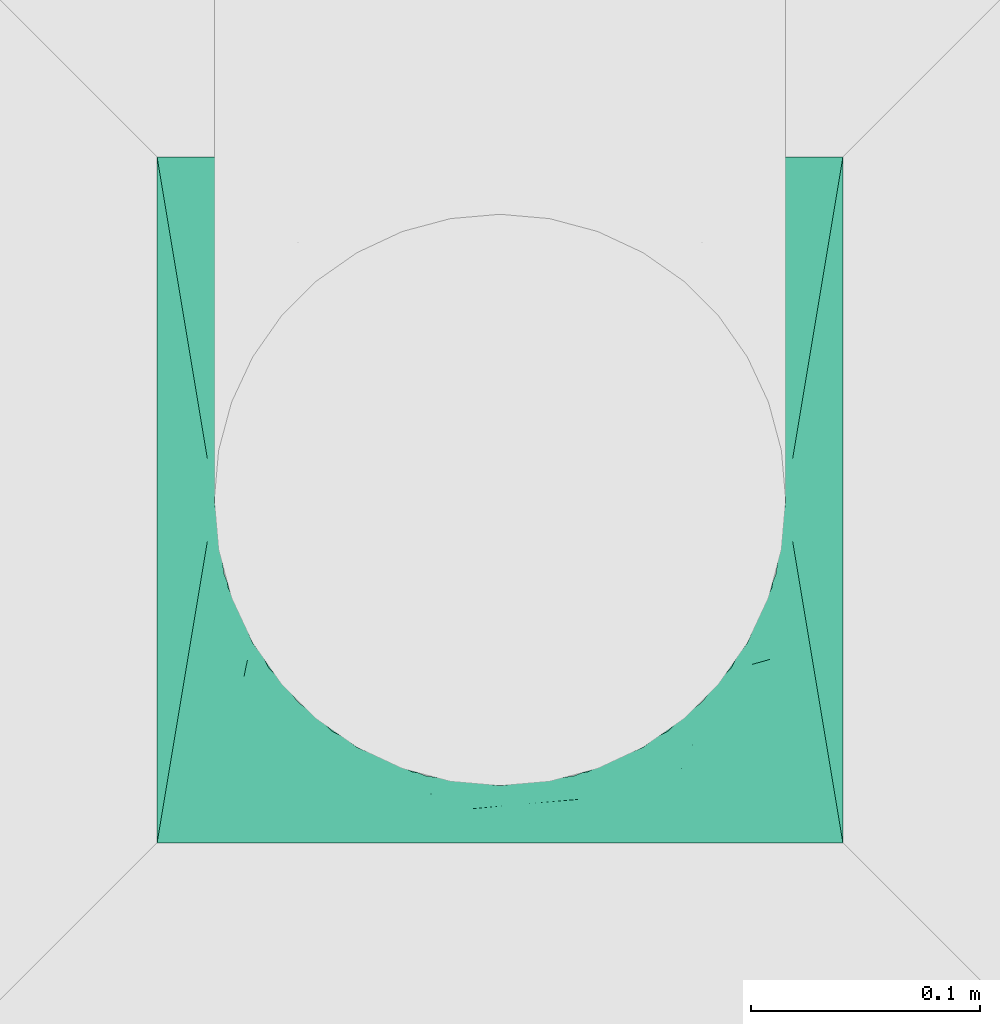
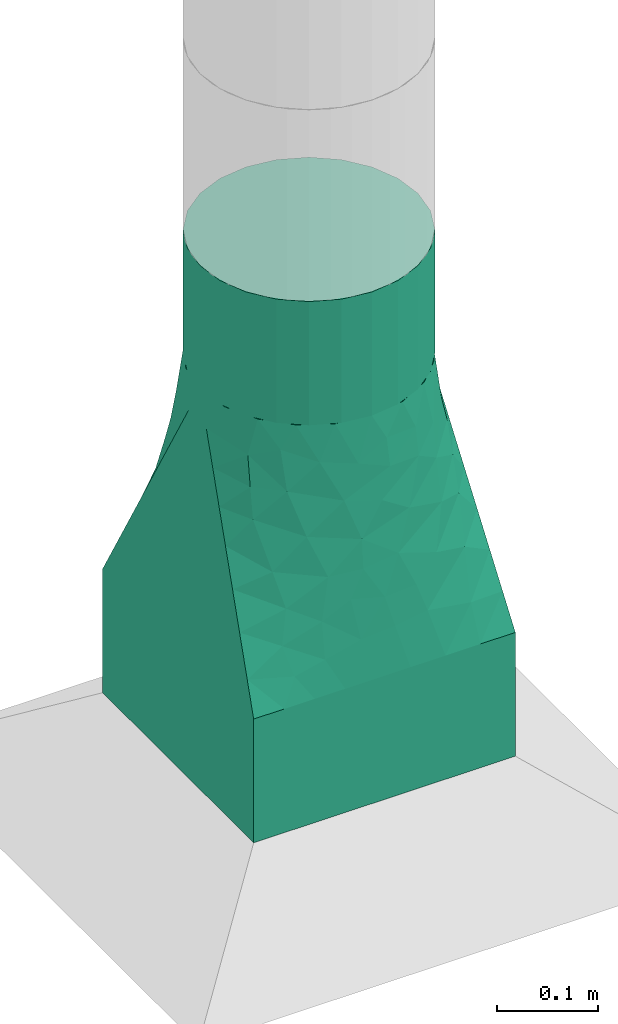
# One storey, part 3 of 6: 1 flow fitting.
"""IFC2X3 building model written with IfcOpenShell, lengths in metres."""

from ifc_helpers import new_model, entity, si_unit, converted_unit, derived_unit, direction, frame, origin, place, context, subcontext, project, spatial, faceted_brep, source, transform, mapped, type_object, type_shapes, element, save


model = new_model("IFC2X3")

# Units and contexts
model_context = context("Model", 3, precision=1e-05, world=origin(), true_north=direction((6.12303176911189e-17, 1.0)))
body_context = subcontext(model_context, "Body", "Model", "MODEL_VIEW")
ifc_project = project(units=[si_unit("LENGTHUNIT", "METRE"), si_unit("AREAUNIT", "SQUARE_METRE"), si_unit("VOLUMEUNIT", "CUBIC_METRE"), converted_unit("PLANEANGLEUNIT", "DEGREE", entity("IfcRatioMeasure", 0.0174532925199433), si_unit("PLANEANGLEUNIT", "RADIAN"), dimensions=[0, 0, 0, 0, 0, 0, 0]), si_unit("MASSUNIT", "GRAM", prefix="KILO"), derived_unit("MASSDENSITYUNIT", [(si_unit("MASSUNIT", "GRAM", prefix="KILO"), 1), (si_unit("LENGTHUNIT", "METRE"), -3)]), si_unit("TIMEUNIT", "SECOND"), si_unit("FREQUENCYUNIT", "HERTZ"), si_unit("THERMODYNAMICTEMPERATUREUNIT", "DEGREE_CELSIUS"), derived_unit("THERMALTRANSMITTANCEUNIT", [(si_unit("MASSUNIT", "GRAM", prefix="KILO"), 1), (si_unit("THERMODYNAMICTEMPERATUREUNIT", "KELVIN"), -1), (si_unit("TIMEUNIT", "SECOND"), -3)]), derived_unit("VOLUMETRICFLOWRATEUNIT", [(si_unit("LENGTHUNIT", "METRE"), 3), (si_unit("TIMEUNIT", "SECOND"), -1)]), si_unit("ELECTRICCURRENTUNIT", "AMPERE"), si_unit("ELECTRICVOLTAGEUNIT", "VOLT"), si_unit("POWERUNIT", "WATT"), si_unit("FORCEUNIT", "NEWTON", prefix="KILO"), si_unit("ILLUMINANCEUNIT", "LUX"), si_unit("LUMINOUSFLUXUNIT", "LUMEN"), si_unit("LUMINOUSINTENSITYUNIT", "CANDELA"), derived_unit("USERDEFINED", [(si_unit("MASSUNIT", "GRAM", prefix="KILO"), -1), (si_unit("LENGTHUNIT", "METRE"), -2), (si_unit("TIMEUNIT", "SECOND"), 3), (si_unit("LUMINOUSFLUXUNIT", "LUMEN"), 1)]), derived_unit("LINEARVELOCITYUNIT", [(si_unit("LENGTHUNIT", "METRE"), 1), (si_unit("TIMEUNIT", "SECOND"), -1)]), si_unit("PRESSUREUNIT", "PASCAL"), derived_unit("USERDEFINED", [(si_unit("LENGTHUNIT", "METRE"), -2), (si_unit("MASSUNIT", "GRAM", prefix="KILO"), 1), (si_unit("TIMEUNIT", "SECOND"), -2)])], contexts=[model_context])

# Site, building, storey
site_placement = place(None, origin())
site = spatial("IfcSite", under=ifc_project, at=site_placement, CompositionType="ELEMENT")
building_placement = place(site_placement, origin())
building = spatial("IfcBuilding", under=site, at=building_placement, CompositionType="ELEMENT")
storey_placement = place(building_placement, origin())
storey = spatial("IfcBuildingStorey", under=building, at=storey_placement, Name="1 - RDC", CompositionType="ELEMENT", Elevation=1.94210219716249e-13)

# Flow fitting
duct_fitting_type = type_object("IfcDuctFittingType", Name="Standard", PredefinedType="NOTDEFINED")
shared_shape = source(origin(), body_context, "Body", "Brep", [
    faceted_brep([(0.6, 0.0323523806378222, -0.120740728286125), (0.6, 0.0625000000000071, -0.108253175473047), (0.6, 0.0883883476483257, -0.0883883476483103), (0.6, 0.108253175473062, -0.062499999999992), (0.6, 0.120740728286141, -0.0323523806378072), (0.6, 0.125000000000008, 0.0), (0.6, 0.120740728286141, 0.0323523806378237), (0.6, 0.108253175473063, 0.0625000000000085), (0.6, 0.0883883476483262, 0.088388347648327), (0.6, 0.0625000000000078, 0.108253175473063), (0.6, 0.032352380637823, 0.120740728286142), (0.6, 0.0, 0.125000000000009), (0.6, -0.0323523806378072, 0.120740728286142), (0.6, -0.0624999999999921, 0.108253175473064), (0.6, -0.0883883476483105, 0.0883883476483273), (0.6, -0.108253175473047, 0.0625000000000089), (0.6, -0.120740728286126, 0.0323523806378241), (0.6, -0.124999999999992, 0.0), (0.6, -0.120740728286126, -0.0323523806378061), (0.6, -0.108253175473047, -0.062499999999991), (0.6, -0.0883883476483111, -0.0883883476483095), (0.6, -0.0624999999999927, -0.108253175473046), (0.6, -0.0323523806378079, -0.120740728286125), (0.6, 0.0, -0.124999999999991), (0.45, 0.032352380637823, 0.120740728286142), (0.45, 0.0625000000000078, 0.108253175473063), (0.45, 0.0883883476483262, 0.088388347648327), (0.45, 0.108253175473063, 0.0625000000000085), (0.45, 0.120740728286141, 0.0323523806378237), (0.45, 0.125000000000008, 0.0), (0.45, 0.120740728286141, -0.0323523806378072), (0.45, 0.108253175473062, -0.062499999999992), (0.45, 0.0883883476483257, -0.0883883476483103), (0.45, 0.0625000000000071, -0.108253175473047), (0.45, 0.0323523806378222, -0.120740728286125), (0.45, 0.0, -0.124999999999991), (0.45, -0.0323523806378079, -0.120740728286125), (0.45, -0.0624999999999927, -0.108253175473046), (0.45, -0.0883883476483111, -0.0883883476483095), (0.45, -0.108253175473047, -0.062499999999991), (0.45, -0.120740728286126, -0.0323523806378061), (0.45, -0.124999999999992, 0.0), (0.45, -0.120740728286126, 0.0323523806378241), (0.45, -0.108253175473047, 0.0625000000000089), (0.45, -0.0883883476483105, 0.0883883476483273), (0.45, -0.0624999999999921, 0.108253175473064), (0.45, -0.0323523806378072, 0.120740728286142), (0.45, 0.0, 0.125000000000009)], [[[0, 1, 2, 3, 4, 5, 6, 7, 8, 9, 10, 11, 12, 13, 14, 15, 16, 17, 18, 19, 20, 21, 22, 23]], [[24, 25, 26, 27, 28, 29, 30, 31, 32, 33, 34, 35, 36, 37, 38, 39, 40, 41, 42, 43, 44, 45, 46, 47]], [[18, 40, 39, 19]], [[38, 20, 19, 39]], [[21, 37, 36, 22]], [[38, 37, 21, 20]], [[22, 36, 35, 23]], [[40, 18, 17, 41]], [[0, 34, 33, 1]], [[32, 2, 1, 33]], [[3, 31, 30, 4]], [[32, 31, 3, 2]], [[4, 30, 29, 5]], [[34, 0, 23, 35]], [[6, 5, 29, 28]], [[7, 6, 28, 27]], [[9, 25, 24, 10]], [[47, 11, 10, 24]], [[26, 8, 7, 27]], [[26, 25, 9, 8]], [[12, 46, 45, 13]], [[44, 14, 13, 45]], [[15, 43, 42, 16]], [[44, 43, 15, 14]], [[16, 42, 41, 17]], [[46, 12, 11, 47]]]),
    faceted_brep([(0.15, -0.15, 0.150000000000001), (0.15, -0.15, -0.149999999999999), (0.15, 0.149999999999999, -0.149999999999999), (0.15, 0.149999999999999, 0.150000000000001), (0.0, -0.15, 0.150000000000001), (0.0, 0.149999999999999, 0.150000000000001), (0.0, 0.149999999999999, -0.149999999999999), (0.0, -0.15, -0.149999999999999)], [[[0, 1, 2, 3]], [[4, 5, 6, 7]], [[1, 0, 4, 7]], [[2, 1, 7, 6]], [[3, 2, 6, 5]], [[0, 3, 5, 4]]]),
    faceted_brep([(0.45, 0.0, 0.125000000000009), (0.45, -0.0386271242968605, 0.118882064536903), (0.45, -0.0734731565365512, 0.101127124296877), (0.45, -0.101127124296861, 0.073473156536568), (0.45, -0.118882064536886, 0.0386271242968774), (0.45, -0.124999999999992, 0.0), (0.45, -0.118882064536887, -0.0386271242968595), (0.45, -0.101127124296861, -0.0734731565365502), (0.45, -0.0734731565365518, -0.10112712429686), (0.45, -0.0386271242968613, -0.118882064536885), (0.45, 0.0, -0.124999999999991), (0.45, 0.0386271242968755, -0.118882064536886), (0.45, 0.0734731565365663, -0.10112712429686), (0.45, 0.101127124296876, -0.0734731565365511), (0.45, 0.118882064536902, -0.0386271242968606), (0.45, 0.125000000000008, 0.0), (0.45, 0.118882064536902, 0.038627124296877), (0.45, 0.101127124296876, 0.0734731565365677), (0.45, 0.0734731565365669, 0.101127124296877), (0.45, 0.0386271242968763, 0.118882064536903), (0.15, 0.149999999999999, -0.149999999999999), (0.15, 0.109961175269853, -0.149999999999999), (0.15, 0.0699223505397056, -0.149999999999999), (0.15, 0.0298835258095585, -0.149999999999999), (0.15, -0.0101552989205884, -0.149999999999999), (0.15, -0.0451164741904414, -0.149999999999999), (0.15, -0.0800776494602944, -0.149999999999999), (0.15, -0.115038824730147, -0.149999999999999), (0.15, -0.15, -0.149999999999999), (0.15, -0.15, 0.150000000000001), (0.15, -0.109961175269853, 0.150000000000001), (0.15, -0.0699223505397063, 0.150000000000001), (0.15, -0.0298835258095593, 0.150000000000001), (0.15, 0.0101552989205878, 0.150000000000001), (0.15, 0.0451164741904407, 0.150000000000001), (0.15, 0.0800776494602936, 0.150000000000001), (0.15, 0.115038824730147, 0.150000000000001), (0.15, 0.149999999999999, 0.150000000000001), (0.185675806788791, -0.147027016100933, -0.132162096605603), (0.228648386422417, -0.14344596779813, -0.110675806788788), (0.267972579633625, -0.140168951697195, -0.0910137101831831), (0.307296772844835, -0.13689193559626, -0.0713516135775775), (0.342972579633627, -0.133918951697193, -0.0535137101831806), (0.378648386422417, -0.130945967798126, -0.0356758067887842), (0.414324193211208, -0.127972983899059, -0.0178379033943879), (0.414324183016787, -0.127972984748594, 0.0178379084916147), (0.37864838631433, -0.130945967807133, 0.0356758068428423), (0.342972569331116, -0.133918952555735, 0.053513715334448), (0.307296752347903, -0.136891937304338, 0.0713516238260537), (0.267972569331116, -0.140168952555737, 0.091013715334446), (0.22864838631433, -0.143445967807137, 0.110675806842838), (0.189324203297543, -0.146722983058537, 0.130337898351231), (0.407779426863444, -0.05509534473452, -0.116811597641384), (0.420565846065319, -0.0870747690980912, -0.0944333005042857), (0.37492063615484, -0.0850377294350482, -0.103807552119239), (0.407779424997341, -0.110478517630006, -0.069872535353113), (0.414324203297543, 0.127972983058545, -0.0178378983512216), (0.325012046694359, -0.0717303187290657, -0.119748977707757), (0.312975795993598, -0.0174741475012942, -0.135582640240139), (0.361008549137171, -0.0338180206764952, -0.128640756913836), (0.41881495601553, 0.0160390158069551, -0.12662598048584), (0.277979222904299, -0.0543876326753398, -0.132438162718547), (0.412166085849056, 0.0552671391842867, -0.11624682673834), (0.385174825807102, 0.0185702013326801, -0.129195683593748), (0.35023235736211, 0.00695757257286128, -0.133161687370925), (0.378285465332651, 0.0568677092987935, -0.119395582892139), (0.189324183016787, 0.146722984748602, -0.130337908491605), (0.193314032806637, 0.107047065091144, -0.136334013163501), (0.373930631518513, -0.1120249018076, -0.0774763040236562), (0.340077999210493, -0.113777785509305, -0.0859517180586173), (0.32812114214319, 0.0395079399030371, -0.130543506310971), (0.283274024599807, 0.0232474382556584, -0.137616424350876), (0.397399320539831, 0.0845002566519246, -0.100424648172396), (0.358946611920716, 0.0843248469552261, -0.107088170421505), (0.401189676220562, 0.110338468230205, -0.0719208742616482), (0.310037819927421, 0.0854873259020617, -0.115364435150938), (0.337379459802237, 0.116271032149025, -0.0840484970713062), (0.399944164229103, -0.0172325795277494, -0.128094264925727), (0.370642967467547, 0.118166417987706, -0.0697060329600357), (0.278791702813727, -0.0176437263232622, -0.138551805429461), (0.205756583217155, 0.0540737656971674, -0.142029911334702), (0.239258535419748, 0.0426900256803068, -0.139426146678018), (0.202394234496035, 0.0150670252485317, -0.145389249231808), (0.211470987726484, -0.106286526921949, -0.130897710850366), (0.249109077485942, -0.0974095542101352, -0.123271105363797), (0.287665148067941, -0.104848365562891, -0.109186455477128), (0.178613678791047, -0.0984225266329105, -0.141916378681063), (0.23000520557385, -0.0640766997130127, -0.136868303383999), (0.247831393765059, -0.0326257698549697, -0.139875142969508), (0.199496898728352, -0.0242636609254632, -0.145273067572237), (0.239369440480427, 0.00487437173411708, -0.14251186564137), (0.262708817838518, 0.0710709365734255, -0.129851624011797), (0.248310480327612, 0.11051697548682, -0.117900556909347), (0.299858839780963, 0.115061209181413, -0.098096704942714), (0.267972589611872, 0.14016895086568, -0.0910137051940602), (0.307296772628659, 0.136891935614282, -0.0713516136856659), (0.22864838631433, 0.143445967807141, -0.110675806842832), (0.342972569331116, 0.133918952555745, -0.0535137153344365), (0.37864838631433, 0.130945967807145, -0.035675806842829), (0.188077660394615, -0.0644584168832844, -0.143524793783479), (0.185675806788792, 0.147027016100934, 0.132162096605606), (0.228648386422418, 0.143445967798133, 0.110675806788794), (0.267972579633626, 0.140168951697201, 0.0910137101831911), (0.307296772844835, 0.136891935596268, 0.0713516135775875), (0.342972579633627, 0.133918951697203, 0.0535137101831925), (0.378648386422418, 0.130945967798138, 0.0356758067887981), (0.414324193211208, 0.127972983899073, 0.0178379033944036), (0.407779426863444, 0.0550953447345328, 0.116811597641399), (0.420565846065319, 0.0870747690981048, 0.0944333005043017), (0.37492063615484, 0.0850377294350594, 0.103807552119252), (0.407779424997341, 0.110478517630019, 0.0698725353531284), (0.325012046694359, 0.0717303187290742, 0.119748977707768), (0.312975795993598, 0.017474147501302, 0.13558264024015), (0.361008549137171, 0.0338180206765055, 0.128640756913849), (0.41881495601553, -0.0160390158069417, 0.126625980485855), (0.277979222904299, 0.0543876326753458, 0.132438162718555), (0.412166085849056, -0.0552671391842736, 0.116246826738355), (0.385174825807102, -0.0185702013326686, 0.129195683593762), (0.35023235736211, -0.00695757257285159, 0.133161687370937), (0.378285465332651, -0.0568677092987823, 0.119395582892152), (0.193314032806637, -0.107047065091143, 0.136334013163505), (0.373930631518513, 0.112024901807611, 0.0774763040236699), (0.340077999210493, 0.113777785509314, 0.0859517180586292), (0.32812114214319, -0.0395079399030286, 0.130543506310982), (0.283274024599807, -0.023247438255652, 0.137616424350885), (0.397399320539831, -0.0845002566519122, 0.10042464817241), (0.358946611920716, -0.0843248469552158, 0.107088170421517), (0.401189676220562, -0.110338468230192, 0.0719208742616627), (0.310037819927421, -0.0854873259020542, 0.115364435150948), (0.337379459802237, -0.116271032149016, 0.0840484970713174), (0.399944164229103, 0.0172325795277618, 0.128094264925742), (0.370642967467547, -0.118166417987695, 0.0697060329600486), (0.278791702813727, 0.0176437263232682, 0.138551805429469), (0.205756583217155, -0.0540737656971653, 0.142029911334707), (0.239258535419748, -0.042690025680303, 0.139426146678024), (0.202394234496036, -0.0150670252485298, 0.145389249231812), (0.211470987726485, 0.106286526921951, 0.130897710850371), (0.249109077485942, 0.0974095542101395, 0.123271105363805), (0.287665148067941, 0.104848365562898, 0.109186455477138), (0.178613678791047, 0.0984225266329113, 0.141916378681066), (0.23000520557385, 0.0640766997130158, 0.136868303384005), (0.24783139376506, 0.0326257698549739, 0.139875142969515), (0.199496898728352, 0.0242636609254647, 0.145273067572242), (0.239369440480428, -0.00487437173411328, 0.142511865641377), (0.262708817838518, -0.0710709365734204, 0.129851624011805), (0.248310480327612, -0.110516975486815, 0.117900556909354), (0.299858839780963, -0.115061209181406, 0.0980967049427232), (0.188077660394615, 0.0644584168832854, 0.143524793783483)], [[[0, 1, 2, 3, 4, 5, 6, 7, 8, 9, 10, 11, 12, 13, 14, 15, 16, 17, 18, 19]], [[20, 21, 22, 23, 24, 25, 26, 27, 28, 29, 30, 31, 32, 33, 34, 35, 36, 37]], [[29, 28, 38, 39, 40, 41, 42, 43, 44, 5, 45, 46, 47, 48, 49, 50, 51]], [[52, 53, 54]], [[7, 6, 55]], [[15, 14, 56]], [[57, 58, 59]], [[10, 60, 11]], [[9, 8, 52]], [[58, 57, 61]], [[6, 44, 55]], [[62, 60, 63]], [[64, 65, 63]], [[21, 66, 67]], [[68, 42, 69]], [[70, 58, 71]], [[72, 13, 12]], [[73, 65, 70]], [[14, 13, 74]], [[8, 7, 53]], [[11, 62, 12]], [[75, 76, 73]], [[70, 75, 73]], [[52, 77, 9]], [[55, 53, 7]], [[56, 14, 74]], [[52, 54, 59]], [[72, 12, 62]], [[78, 73, 76]], [[54, 53, 55]], [[54, 68, 69]], [[54, 57, 59]], [[77, 63, 60]], [[63, 65, 62]], [[62, 65, 72]], [[64, 58, 70]], [[77, 59, 63]], [[58, 61, 79]], [[80, 81, 82]], [[54, 69, 57]], [[39, 83, 84]], [[69, 41, 85]], [[27, 26, 86]], [[54, 55, 68]], [[39, 84, 40]], [[55, 43, 68]], [[57, 69, 85]], [[85, 84, 61]], [[85, 61, 57]], [[61, 87, 88]], [[89, 90, 88]], [[81, 80, 91]], [[89, 82, 90]], [[80, 67, 92]], [[91, 92, 93]], [[67, 80, 22]], [[67, 22, 21]], [[94, 95, 93]], [[63, 59, 64]], [[72, 73, 74]], [[88, 79, 61]], [[70, 71, 75]], [[73, 72, 65]], [[13, 72, 74]], [[92, 96, 94]], [[75, 93, 76]], [[92, 67, 96]], [[93, 95, 76]], [[92, 91, 80]], [[76, 95, 97]], [[74, 78, 98]], [[81, 71, 90]], [[75, 71, 91]], [[11, 60, 62]], [[10, 9, 77]], [[77, 60, 10]], [[59, 77, 52]], [[91, 93, 75]], [[94, 93, 92]], [[74, 98, 56]], [[44, 6, 5]], [[44, 43, 55]], [[8, 53, 52]], [[38, 28, 27]], [[66, 21, 20]], [[25, 89, 99]], [[85, 41, 40]], [[42, 68, 43]], [[42, 41, 69]], [[89, 88, 87]], [[79, 90, 71]], [[99, 89, 87]], [[23, 82, 24]], [[90, 79, 88]], [[71, 58, 79]], [[99, 86, 26]], [[25, 24, 89]], [[83, 99, 87]], [[84, 83, 87]], [[38, 83, 39]], [[86, 99, 83]], [[27, 86, 38]], [[38, 86, 83]], [[99, 26, 25]], [[80, 23, 22]], [[61, 84, 87]], [[40, 84, 85]], [[71, 81, 91]], [[82, 81, 90]], [[58, 64, 59]], [[66, 96, 67]], [[65, 64, 70]], [[73, 78, 74]], [[78, 97, 98]], [[97, 78, 76]], [[24, 82, 89]], [[23, 80, 82]], [[56, 98, 97, 95, 94, 96, 66, 20, 37, 100, 101, 102, 103, 104, 105, 106, 15]], [[107, 108, 109]], [[17, 16, 110]], [[5, 4, 45]], [[111, 112, 113]], [[0, 114, 1]], [[19, 18, 107]], [[112, 111, 115]], [[16, 106, 110]], [[116, 114, 117]], [[118, 119, 117]], [[30, 51, 120]], [[121, 104, 122]], [[123, 112, 124]], [[125, 3, 2]], [[126, 119, 123]], [[4, 3, 127]], [[18, 17, 108]], [[1, 116, 2]], [[128, 129, 126]], [[123, 128, 126]], [[107, 130, 19]], [[110, 108, 17]], [[45, 4, 127]], [[107, 109, 113]], [[125, 2, 116]], [[131, 126, 129]], [[109, 108, 110]], [[109, 121, 122]], [[109, 111, 113]], [[130, 117, 114]], [[117, 119, 116]], [[116, 119, 125]], [[118, 112, 123]], [[130, 113, 117]], [[112, 115, 132]], [[133, 134, 135]], [[109, 122, 111]], [[101, 136, 137]], [[122, 103, 138]], [[36, 35, 139]], [[109, 110, 121]], [[101, 137, 102]], [[110, 105, 121]], [[111, 122, 138]], [[138, 137, 115]], [[138, 115, 111]], [[115, 140, 141]], [[142, 143, 141]], [[134, 133, 144]], [[142, 135, 143]], [[133, 120, 145]], [[144, 145, 146]], [[120, 133, 31]], [[120, 31, 30]], [[49, 48, 146]], [[117, 113, 118]], [[125, 126, 127]], [[141, 132, 115]], [[123, 124, 128]], [[126, 125, 119]], [[3, 125, 127]], [[145, 50, 49]], [[128, 146, 129]], [[145, 120, 50]], [[146, 48, 129]], [[145, 144, 133]], [[129, 48, 47]], [[127, 131, 46]], [[134, 124, 143]], [[128, 124, 144]], [[1, 114, 116]], [[0, 19, 130]], [[130, 114, 0]], [[113, 130, 107]], [[144, 146, 128]], [[49, 146, 145]], [[127, 46, 45]], [[106, 16, 15]], [[106, 105, 110]], [[18, 108, 107]], [[100, 37, 36]], [[51, 30, 29]], [[34, 142, 147]], [[138, 103, 102]], [[104, 121, 105]], [[104, 103, 122]], [[142, 141, 140]], [[132, 143, 124]], [[147, 142, 140]], [[32, 135, 33]], [[143, 132, 141]], [[124, 112, 132]], [[147, 139, 35]], [[34, 33, 142]], [[136, 147, 140]], [[137, 136, 140]], [[100, 136, 101]], [[139, 147, 136]], [[36, 139, 100]], [[100, 139, 136]], [[147, 35, 34]], [[133, 32, 31]], [[115, 137, 140]], [[102, 137, 138]], [[124, 134, 144]], [[135, 134, 143]], [[112, 118, 113]], [[51, 50, 120]], [[119, 118, 123]], [[126, 131, 127]], [[131, 47, 46]], [[47, 131, 129]], [[33, 135, 142]], [[32, 133, 135]]]),
])
type_shapes(duct_fitting_type, [shared_shape])
flow_fitting_placement = place(storey_placement, frame((14.2727214734544, -4.38751978878919, 2.6016), z_axis=(0.0, -1.0, 0.0), x_axis=(0.0, 0.0, 1.0)))
element("IfcFlowFitting", 1, at=flow_fitting_placement, inside=storey, type_object=duct_fitting_type, ObjectType="Standard", context=body_context, shape_type="MappedRepresentation", body=[
    mapped(shared_shape, transform((0.0, 0.0, 0.0), scale=1.0)),
])

save(model, "model.ifc")
